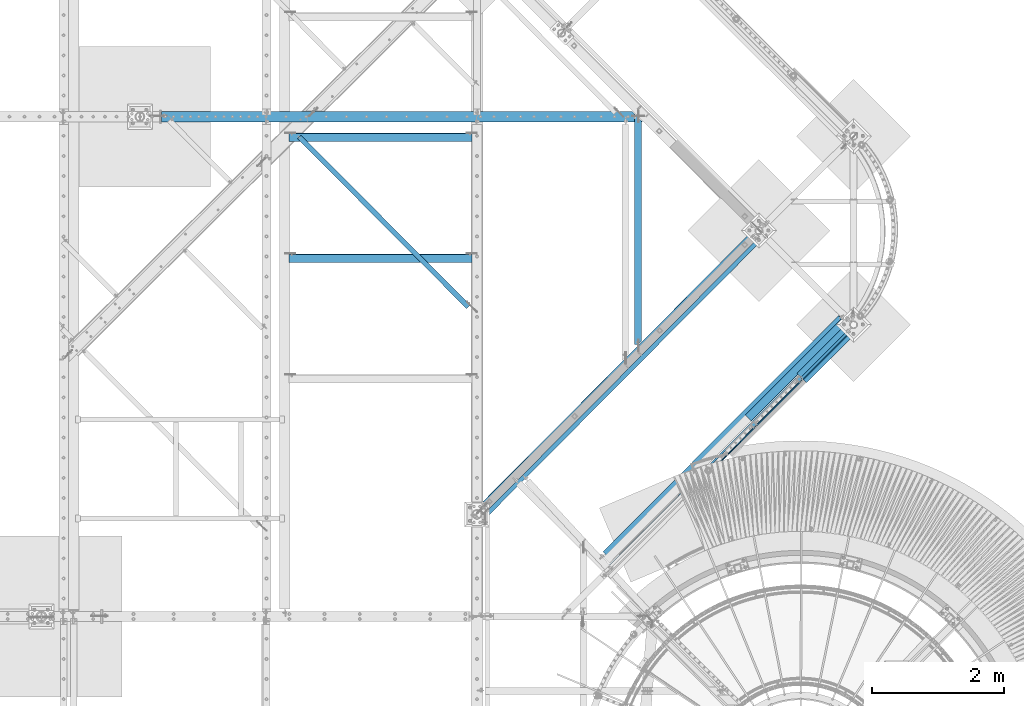
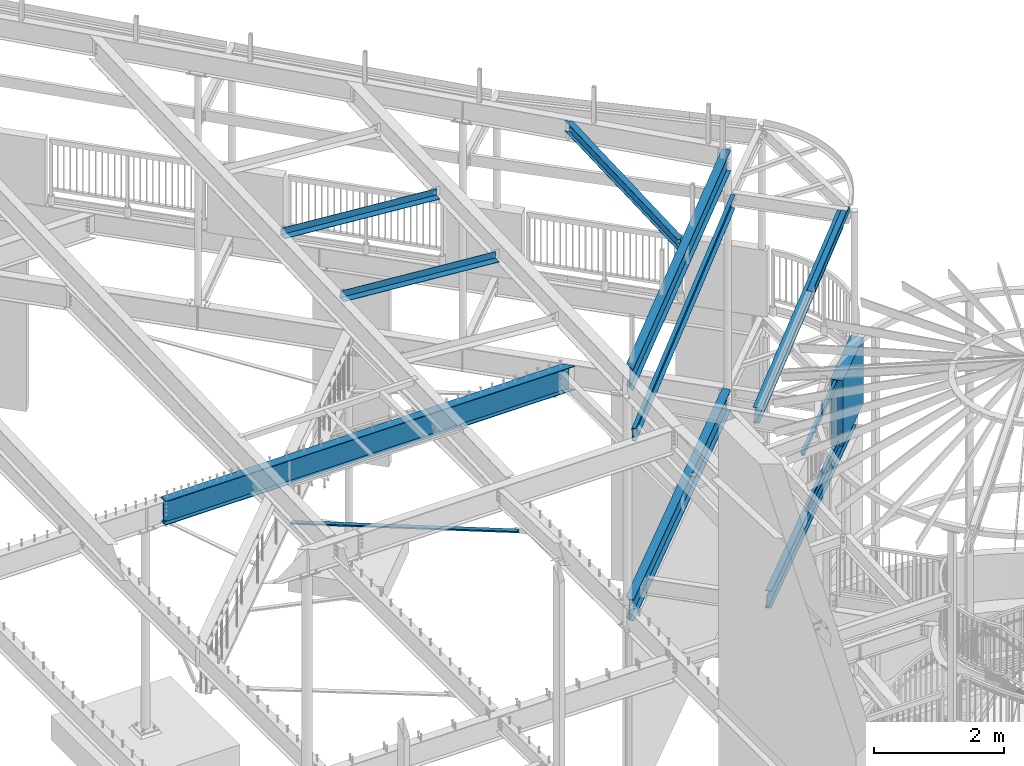
# One storey, part 369 of 975: 14 beams.
"""IFC2X3 building model written with IfcOpenShell, lengths in millimetres."""

from ifc_helpers import new_model, si_unit, frame, origin_with_axes, place, context, subcontext, project, spatial, faceted_brep, material, type_object, element, save


model = new_model("IFC2X3")

# Units and contexts
model_context = context("Model", 3, precision=1e-05, world=origin_with_axes())
body_context = subcontext(model_context, "Body", "Model", "MODEL_VIEW")
ifc_project = project(units=[si_unit("LENGTHUNIT", "METRE", prefix="MILLI"), si_unit("AREAUNIT", "SQUARE_METRE"), si_unit("VOLUMEUNIT", "CUBIC_METRE"), si_unit("MASSUNIT", "GRAM", prefix="KILO"), si_unit("TIMEUNIT", "SECOND"), si_unit("PLANEANGLEUNIT", "RADIAN"), si_unit("SOLIDANGLEUNIT", "STERADIAN"), si_unit("THERMODYNAMICTEMPERATUREUNIT", "DEGREE_CELSIUS"), si_unit("LUMINOUSINTENSITYUNIT", "LUMEN")], contexts=[model_context])

# Site, building, storey
site_placement = place(None, origin_with_axes())
site = spatial("IfcSite", under=ifc_project, at=site_placement, CompositionType="ELEMENT")
building_placement = place(site_placement, origin_with_axes())
building = spatial("IfcBuilding", under=site, at=building_placement, Name="Undefined", CompositionType="ELEMENT")
storey_placement = place(building_placement, origin_with_axes())
storey = spatial("IfcBuildingStorey", under=building, at=storey_placement, Name="Undefined", CompositionType="ELEMENT", Elevation=0.0)

# Beams
ifc_material_1 = material(Name="STEEL/A36")
beam_type_1 = type_object("IfcBeamType", Name="L3X3X3/16", PredefinedType="NOTDEFINED")
beam_1_placement = place(storey_placement, frame((27168.4576341106, 13059.2154433271, 2870.2), z_axis=(-0.709199630836852, -0.705007718837796, 0.0), x_axis=(0.0, 0.0, 1.0)))
element("IfcBeam", 1, at=beam_1_placement, inside=storey, type_object=beam_type_1, material=ifc_material_1, Name="ANGLE", ObjectType="L3X3X3/16", context=body_context, shape_type="Brep", body=[
    faceted_brep([(25.4000008288263, 33.3375000029282, 38.0998593531185), (25.4000000579194, 38.1000000029326, 38.0998593531222), (25.4000000057686, 38.1000000029999, -38.1001406479627), (25.4000007766758, 33.337499976793, -38.0997502874998), (25.400000779935, 33.3375000029864, -33.3376406479038), (87.9265310704686, 33.3375000605593, -33.3379868761476), (87.9265310672095, 33.3374998672407, -38.1002658450525), (17.1664076945221, 23.5263180373422, -38.1000950560956), (17.1664578788032, 23.5263251884717, -33.3375950563059), (25.7799495100917, -38.5952650544987, -33.338294942936), (25.7107114156174, -38.0999999970863, -33.337642368464), (25.7106039629884, -38.0999999970791, -38.1001423679409), (25.7799104735986, -38.5951737114028, -38.1007949418963), (519.883321706701, -3602.16366419144, -38.1731929346388), (519.883347554101, -3602.16366041227, -33.4106929337468), (101.257834322486, -28.1298494790972, -38.1012128859002), (92.0741449431193, 38.1000000106342, -38.1005098427995), (92.0758641851835, 38.1000000105723, 38.099490148772), (101.258458906369, -28.1313109686234, 38.0987870974495), (595.361659118978, -3591.69827952844, 38.0263891356226), (595.361245560576, -3591.69833999513, -38.173610878639), (96.5410886658128, -28.7853937331438, 38.098813218945), (590.64428887811, -3592.35236229071, 38.0264152571253), (590.643901167109, -3592.35241897823, -33.4110847562479), (87.928142873925, 33.3375000100896, 38.0995131159507), (96.5405031184227, -28.7840235867134, -33.3386867654408)], [[[0, 1, 2, 3, 4]], [[5, 6, 7, 8]], [[4, 3, 6, 5]], [[9, 10, 11, 12, 13, 14]], [[15, 16, 17, 18, 19, 20]], [[18, 21, 22, 19]], [[23, 14, 13, 20, 19, 22]], [[21, 24, 5, 25, 23, 22]], [[10, 9, 14, 23, 25, 5, 8]], [[11, 10, 8, 7]], [[2, 16, 15, 20, 13, 12, 11, 7, 6, 3]], [[17, 16, 2, 1]], [[24, 21, 18, 17, 1, 0]], [[5, 24, 0, 4]]]),
])
beam_type_2 = type_object("IfcBeamType", Name="C10X15.3", PredefinedType="NOTDEFINED")
beam_2_placement = place(storey_placement, frame((29910.7374267626, 7300.12961301869, 7137.61804652991), z_axis=(-0.0412871090037879, -0.0415479340038119, 0.998283098028873), x_axis=(0.703666593898344, 0.708111903897702, 0.058573510991538)))
element("IfcBeam", 2, at=beam_2_placement, inside=storey, type_object=beam_type_2, material=ifc_material_1, Name="BEAM", ObjectType="C10X15.3", context=body_context, shape_type="Brep", body=[
    faceted_brep([(-1.70985003933311e-10, 33.3375000000001, -126.999999999975), (1.78260961547494e-10, 33.3375000000001, 126.999999999975), (6001.03386350567, 33.3375000025826, 127.000000000959), (5986.13060427879, 33.337500002357, -126.999999999053), (1.78260961547494e-10, -33.3375000000001, 126.999999999975), (6001.03386353988, -33.3374999974276, 127.000000000962), (1.70985003933311e-10, -33.3375000000001, 121.441527499974), (6000.70772434078, -33.3374999974294, 121.441527500961), (1.52795109897852e-10, 26.9875000000002, 111.391382499978), (6000.11803960036, 26.9875000025695, 111.391382500958), (-1.4915713109076e-10, 26.9875000000002, -111.391382499976), (5987.04642819061, 26.9875000023676, -111.391382499053), (-1.63709046319127e-10, -33.3375000000001, -121.44152749997), (5986.45674351211, -33.3374999976459, -121.441527499051), (-1.70985003933311e-10, -33.3375000000001, -126.999999999975), (5986.130604313, -33.3374999976513, -126.99999999905)], [[[0, 1, 2, 3]], [[1, 4, 5, 2]], [[4, 6, 7, 5]], [[6, 8, 9, 7]], [[8, 10, 11, 9]], [[10, 12, 13, 11]], [[12, 14, 15, 13]], [[14, 0, 3, 15]], [[5, 7, 9, 11, 13, 15, 3, 2]], [[14, 12, 10, 8, 6, 4, 1, 0]]]),
])
ifc_material_2 = material()
beam_type_3 = type_object("IfcBeamType", Name="HSS2X4X.188_TUBES", PredefinedType="NOTDEFINED")
beam_3_placement = place(storey_placement, frame((33335.0272322989, 8032.31295386229, 5130.8), z_axis=(0.0, 0.0, 1.0), x_axis=(0.706220613094393, 0.70799184009463, 0.0)))
element("IfcBeam", 3, at=beam_3_placement, inside=storey, type_object=beam_type_3, material=ifc_material_2, Name="GUARDRAIL", ObjectType="HSS2X4X.188_TUBES", context=body_context, shape_type="Brep", body=[
    faceted_brep([(23.0189099507188, 20.6374999999716, -46.0375000000004), (23.0189099506351, -20.6374999999425, -46.0375000000004), (1932.78143844252, -20.6374999989494, -46.0375000000004), (1932.78143844261, 20.6375000009684, -46.0375000000004), (-23.0189087615618, -20.6374999999716, 46.0375000000004), (1978.81925715473, -20.6374999989275, 46.0375000000004), (-23.0189087614854, 20.6374999999534, 46.0375000000004), (1978.8192571548, 20.6375000009975, 46.0375000000004), (25.40017643584, 25.3999999999687, -50.8000000000002), (-25.4001752465883, 25.3999999999396, 50.8000000000002), (1981.20052363992, 25.4000000009873, 50.8000000000002), (1930.4001719575, 25.4000000009619, -50.8000000000002), (-25.4001752466866, -25.3999999999651, 50.8000000000002), (1981.20052363983, -25.3999999989137, 50.8000000000002), (25.4001764357381, -25.399999999936, -50.8000000000002), (1930.4001719574, -25.3999999989428, -50.8000000000002)], [[[0, 1, 2, 3]], [[1, 4, 5, 2]], [[4, 6, 7, 5]], [[6, 0, 3, 7]], [[8, 9, 10, 11]], [[9, 12, 13, 10]], [[12, 14, 15, 13]], [[14, 8, 11, 15]], [[13, 15, 11, 10], [5, 7, 3, 2]], [[14, 12, 9, 8], [6, 4, 1, 0]]]),
])
beam_type_4 = type_object("IfcBeamType", Name="L5X5X5/16", PredefinedType="NOTDEFINED")
for number, where, z_axis, x_axis in (
    (4, (26920.8249998945, 11250.4718563048, 8374.05719665839), (0.0796654699609281, 0.0, 0.996821655511107), (0.996821655511107, 0.0, -0.0796654699609281)),
    (5, (26920.8249998945, 13079.2718563048, 8450.05353907804), (0.0796654699609281, 0.0, 0.996821655511107), (0.996821655511107, 0.0, -0.0796654699609281)),
):
    element("IfcBeam", number, at=place(storey_placement, frame(where, z_axis=z_axis, x_axis=x_axis)), inside=storey, type_object=beam_type_4, material=ifc_material_1, ObjectType="L5X5X5/16", context=body_context, shape_type="Brep", body=[
        faceted_brep([(67.8053474811386, 63.5, -63.5000000000291), (67.805347481346, 63.5, 63.5000000000564), (2852.95282830662, 63.5, 63.5000000004839), (2852.9528283064, 63.5, -63.4999999996035), (67.805347481346, 55.5625, 63.5000000000564), (2852.95282830662, 55.5625, 63.5000000004839), (67.8053474811495, 55.5625, -55.5625000000236), (2852.95282830642, 55.5625, -55.562499999598), (67.8053474811495, -63.5, -55.5625000000236), (2852.95282830642, -63.5, -55.562499999598), (67.8053474811386, -63.5, -63.5000000000291), (2852.9528283064, -63.5, -63.4999999996035)], [[[0, 1, 2, 3]], [[1, 4, 5, 2]], [[4, 6, 7, 5]], [[6, 8, 9, 7]], [[8, 10, 11, 9]], [[10, 0, 3, 11]], [[5, 7, 9, 11, 3, 2]], [[10, 8, 6, 4, 1, 0]]]),
    ])
beam_type_5 = type_object("IfcBeamType", PredefinedType="NOTDEFINED")
beam_4_placement = place(storey_placement, frame((34527.3123904943, 9227.9224403848, 3938.58749694824), z_axis=(-0.706192932930278, -0.708019449930108, 0.0), x_axis=(0.708019449930107, -0.706192932930278, 0.0)))
element("IfcBeam", 6, at=beam_4_placement, inside=storey, type_object=beam_type_5, material=ifc_material_1, Name="DECK_EDGE", context=body_context, shape_type="Brep", body=[
    faceted_brep([(1.03318598121405e-09, -1.58750000000009, -1524.00000000109), (-1.04046193882823e-09, -1.58750000000009, 1524.0000000011), (-1.04046193882823e-09, 1.58750000000009, 1524.0000000011), (1.03318598121405e-09, 1.58750000000009, -1524.00000000109), (47.6250001214066, 1.58750000000009, 1524.00000000113), (47.6250001235167, 1.58750000000009, -1524.00000000107), (50.8000001235196, -1.58750000000009, -1524.00000000106), (50.8000001214168, -1.58750000000009, 1524.00000000113), (47.6250001214503, 96.837499999901, 1524.00000000113), (47.625000123473, 96.8374999999951, -1524.00000000106), (50.8000001234759, 104.502628762961, -1524.00000000106), (50.8000001214605, 104.502628762867, 1524.00000000113), (38.6447461584321, 87.8572448731024, 1524.00000000113), (38.6447461604548, 87.8572448731024, -1524.00000000107), (36.3996819826862, 90.102308757891, 1524.00000000112), (36.3996819847016, 90.102308757891, -1524.00000000107)], [[[0, 1, 2, 3]], [[3, 2, 4, 5]], [[1, 0, 6, 7]], [[5, 4, 8, 9]], [[7, 6, 10, 11]], [[9, 8, 12, 13]], [[8, 4, 2, 1, 7, 11, 14, 12]], [[11, 10, 15, 14]], [[10, 6, 0, 3, 5, 9, 13, 15]], [[14, 15, 13, 12]]]),
])
beam_type_6 = type_object("IfcBeamType", PredefinedType="NOTDEFINED")
beam_5_placement = place(storey_placement, frame((34625.9997480697, 9604.01899476604, 7559.40335706271), z_axis=(-0.704820138136317, -0.706998290775193, -0.0581548769963319), x_axis=(0.708196855160895, -0.706015024160385, 1.72999999439031e-07)))
element("IfcBeam", 7, at=beam_5_placement, inside=storey, type_object=beam_type_6, material=ifc_material_1, Name="DECK_EDGE", context=body_context, shape_type="Brep", body=[
    faceted_brep([(-8.80390871316195e-09, -3.17500000022574, -1035.04999999823), (2.11002770811319e-09, -3.17499999977372, 1035.04999999821), (8.80027073435485e-09, 3.17500000022756, 1035.04999999823), (-2.11730366572738e-09, 3.17499999977372, -1035.04999999822), (127.239425700831, 3.17499986607436, 1035.04999999815), (127.239425684118, 3.17499986562143, -1035.04999999829), (133.589575920003, -3.17500014107372, -1035.04999999831), (133.589575936709, -3.1750001406208, 1035.04999999815), (127.236871721263, 111.12485451768, 1035.049999998), (127.236871710345, 111.12485451143, -1035.04999999845), (133.586871719464, 111.125004751796, 1035.049999998), (133.58687170855, 111.125004745548, -1035.04999999845)], [[[0, 1, 2, 3]], [[3, 2, 4, 5]], [[1, 0, 6, 7]], [[5, 4, 8, 9]], [[4, 2, 1, 7, 10, 8]], [[7, 6, 11, 10]], [[6, 0, 3, 5, 9, 11]], [[10, 11, 9, 8]]]),
])
ifc_material_3 = material(Name="CONCRETE/5000")
beam_type_7 = type_object("IfcBeamType", PredefinedType="NOTDEFINED")
beam_6_placement = place(storey_placement, frame((34754.1236185556, 9432.06344327084, 4559.3), z_axis=(0.0, 0.0, 1.0), x_axis=(0.706311124041062, 0.707901544041155, 0.0)))
element("IfcBeam", 8, at=beam_6_placement, inside=storey, type_object=beam_type_7, material=ifc_material_3, Name="LOW WALL", context=body_context, shape_type="Brep", body=[
    faceted_brep([(8.00355337560177e-11, 101.599999999831, -622.3), (8.00355337560177e-11, 101.599999999831, 622.3), (1219.20000000123, 101.599999998936, 622.3), (1219.20000000123, 101.599999998936, -622.3), (-7.27595761418343e-11, -101.599999999831, 622.3), (1219.20000000109, -101.600000000741, 622.3), (-7.27595761418343e-11, -101.599999999831, -622.3), (1219.20000000109, -101.600000000741, -622.3)], [[[0, 1, 2, 3]], [[1, 4, 5, 2]], [[4, 6, 7, 5]], [[6, 0, 3, 7]], [[5, 7, 3, 2]], [[6, 4, 1, 0]]]),
])
ifc_material_4 = material(Name="STEEL/A992")
beam_type_8 = type_object("IfcBeamType", Name="W8X10", PredefinedType="NOTDEFINED")
beam_7_placement = place(storey_placement, frame((32270.7000000007, 9825.29369643643, 8292.85227477858), z_axis=(0.0, 0.0390147299837681, -0.99923863558426), x_axis=(0.0, 0.99923863558426, 0.0390147299837675)))
element("IfcBeam", 9, at=beam_7_placement, inside=storey, type_object=beam_type_8, material=ifc_material_4, Name="BEAM", ObjectType="W8X10", context=body_context, shape_type="Brep", body=[
    faceted_brep([(160.737852590288, 50.7999999999993, 95.2499999999636), (160.551903363616, 50.7999999999993, 100.012499999964), (3506.64939208805, 50.7999999999993, 100.012499999042), (3506.83534131949, 50.7999999999993, 95.2499999990414), (3616.17310180885, -50.7999999999993, -100.012500001006), (3615.98715257741, -50.7999999999993, -95.250000001005), (119.414067826492, -50.7999999999993, -95.2500000000418), (119.600017053164, -50.7999999999993, -100.012500000041), (168.361770883843, 50.7999999999993, -100.012500000055), (3514.45925980861, 50.7999999999993, -100.012500000978), (119.600017053164, 2.38124999972206, -100.012500000041), (168.175821657171, 50.7999999999993, -95.2500000000546), (119.414067826774, 2.38124999999854, -95.2500000000418), (3555.30834414774, 2.38124999999854, 95.2499999990278), (3562.74631340541, 2.38124999999854, -95.2500000009904), (111.976098759891, 2.38124999999854, 95.2499999999782), (3514.27331057716, 50.7999999999993, -95.2500000009786), (3608.3632340883, -50.7999999999993, 100.012499999014), (3608.54918331974, -50.7999999999993, 95.2499999990114), (3560.0761804915, -2.38124999999854, 95.249999999025), (3567.51414974917, -2.38124999999854, -95.2500000009923), (111.790149532939, 2.38124999972206, 100.012499999977), (111.790149532939, -50.7999999999993, 100.012499999977), (111.976098759611, -50.7999999999993, 95.2499999999782), (111.976098759611, -2.38124999999854, 95.2499999999782), (119.414067826492, -2.38124999999854, -95.2500000000418)], [[[0, 1, 2, 3]], [[4, 5, 6, 7]], [[8, 9, 4, 7, 10]], [[11, 8, 10, 12]], [[13, 14, 12, 15]], [[11, 12, 14, 16]], [[8, 11, 16, 9]], [[14, 13, 3, 2, 17, 18, 19, 20, 5, 4, 9, 16]], [[15, 0, 3, 13]], [[1, 0, 15, 21]], [[17, 2, 1, 21, 22]], [[18, 17, 22, 23]], [[19, 18, 23, 24]], [[20, 19, 24, 25]], [[5, 20, 25, 6]], [[24, 23, 22, 21, 15, 12, 10, 7, 6, 25]]]),
])
beam_type_9 = type_object("IfcBeamType", Name="W12X14", PredefinedType="NOTDEFINED")
beam_8_placement = place(storey_placement, frame((31701.1565014444, 6689.96021302115, 7164.64273981511), z_axis=(0.0410754901247674, 0.0411679811250478, -0.998307568558457), x_axis=(0.70511574104899, 0.7067034690491, 0.0581549530040405)))
element("IfcBeam", 10, at=beam_8_placement, inside=storey, type_object=beam_type_9, material=ifc_material_4, Name="BEAM", ObjectType="W12X14", context=body_context, shape_type="Brep", body=[
    faceted_brep([(25.2283139935607, -2.38124999992942, -119.062499999896), (25.0388399786862, 2.3812500000713, -119.062499999894), (102.641346061158, 2.38125000011496, -119.062500000057), (102.641346061147, -2.38124999988577, -119.062500000056), (107.501425579212, 2.38125000012224, -120.02922992265), (107.501425579201, -2.38124999988213, -120.02922992265), (111.621602047373, 2.38125000012224, -122.782243823133), (111.621602047366, -2.38124999988213, -122.782243823132), (114.374615947854, 2.38125000012951, -126.902420291292), (114.374615947851, -2.38124999987485, -126.902420291291), (115.341345870445, -2.38124999987485, -131.762499809341), (115.341345870453, 2.38125000012587, -131.762499809339), (115.341345870569, 2.38125000013315, -144.462500000049), (115.341345870547, 50.8000000001666, -144.462500000039), (115.341345870544, 50.8000000001703, -150.812500000039), (115.341345870602, -50.799999999901, -150.812499796145), (115.341345870602, -50.7999999999047, -144.462500000061), (115.341345870573, -2.38124999987122, -144.46250000005), (5162.38062903908, 50.8000000028551, 144.462499998789), (5162.38062903895, 2.38125000281434, 144.462499998778), (108.991345869556, 2.38124999999854, 144.462499999994), (108.991345869523, 50.800000000032, 144.462500000005), (96.2913460602103, -2.38124999999854, 119.062500000006), (96.291346060214, 2.38125000000218, 119.062500000006), (11.1672150216582, 2.38124999995489, 119.062499999933), (11.3566890365291, -2.38125000005311, 119.06249999993), (101.151425578257, -2.38124999999854, 120.02922992259), (101.151425578264, 2.38125000000218, 120.029229922589), (105.271602046414, -2.38124999999854, 122.782243823064), (105.271602046421, 2.38125000000582, 122.782243823064), (108.024615946892, -2.38124999999854, 126.902420291218), (108.024615946895, 2.38125000000582, 126.902420291217), (108.991345869472, -2.38125000000218, 131.762499809265), (108.991345869475, 2.38124999999854, 131.762499809264), (5162.38062903881, -50.7999999972235, 150.812499998767), (5162.38062903909, 50.8000000028442, 150.812499998789), (108.991345869523, 50.8000000000284, 150.812500000005), (108.991345869577, -50.8000000000429, 150.812499999982), (5162.38062903881, -50.7999999972199, 144.462499998765), (108.991345869581, -50.8000000000393, 144.462499999981), (5162.38062903893, -2.38124999718639, 144.462499998776), (108.991345869559, -2.38125000000582, 144.462499999993), (5162.38062903889, -2.38124999716092, 93.6624998101788), (5162.38062903889, 2.38125000283981, 93.6624998101788), (5163.34735896147, -2.38124999716456, 88.8024202921251), (5163.34735896148, 2.38125000283981, 88.802420292126), (5166.10037286195, -2.38124999715728, 84.6822438239642), (5166.10037286195, 2.38125000284344, 84.6822438239642), (5170.2205493301, -2.38124999715001, 81.9292299234785), (5170.22054933012, 2.38125000285072, 81.9292299234785), (5175.08062884814, -2.38124999715365, 80.9625000008828), (5175.08062884815, 2.38125000285072, 80.9625000008828), (5212.29092933559, -2.38124999712818, 80.9625000009428), (5212.29880857402, 2.38125000287619, 80.9625000009482), (5224.31300429969, -2.38124999702632, -125.412499999199), (5224.32088353811, 2.38125000297441, -125.412499999194), (5187.78062884838, -2.38124999704814, -125.412499999195), (5187.78062884838, 2.38125000295622, -125.412499999195), (5182.92054933034, -2.38124999704814, -126.379229921779), (5182.92054933034, 2.38125000295258, -126.379229921779), (5178.8003728622, -2.38124999705178, -129.132243822253), (5178.80037286221, 2.38125000295258, -129.132243822253), (5176.04735896172, -2.38124999705178, -133.252420290401), (5176.04735896173, 2.38125000295258, -133.252420290401), (5175.08062903914, -2.38124999704814, -138.112499808442), (5175.08062903915, 2.38125000295258, -138.112499808442), (5175.08062903919, -2.38124999704451, -144.462500001267), (5175.08062903907, -50.799999997078, -144.462500001278), (5175.08062903906, -50.7999999970743, -150.81250000128), (5175.08062903933, 50.800000002997, -150.812500001256), (5175.08062903933, 50.8000000029933, -144.462500001256), (5175.0806290392, 2.38125000295986, -144.462500001267)], [[[0, 1, 2, 3]], [[3, 2, 4, 5]], [[5, 4, 6, 7]], [[7, 6, 8, 9]], [[10, 11, 12, 13, 14, 15, 16, 17]], [[9, 8, 11, 10]], [[18, 19, 20, 21]], [[22, 23, 24, 25]], [[26, 27, 23, 22]], [[28, 29, 27, 26]], [[30, 31, 29, 28]], [[32, 33, 31, 30]], [[34, 35, 36, 37]], [[38, 34, 37, 39]], [[40, 38, 39, 41]], [[37, 36, 21, 20, 33, 32, 41, 39]], [[35, 18, 21, 36]], [[34, 38, 40, 42, 43, 19, 18, 35]], [[44, 45, 43, 42]], [[46, 47, 45, 44]], [[48, 49, 47, 46]], [[50, 51, 49, 48]], [[52, 53, 51, 50]], [[53, 52, 54, 55]], [[54, 56, 57, 55]], [[58, 59, 57, 56]], [[60, 61, 59, 58]], [[62, 63, 61, 60]], [[64, 65, 63, 62]], [[66, 67, 68, 69, 70, 71, 65, 64]], [[67, 66, 17, 16]], [[68, 67, 16, 15]], [[69, 68, 15, 14]], [[70, 69, 14, 13]], [[71, 70, 13, 12]], [[6, 4, 2, 1, 24, 23, 27, 29, 31, 33, 20, 19, 43, 45, 47, 49, 51, 53, 55, 57, 59, 61, 63, 65, 71, 12, 11, 8]], [[25, 24, 1, 0]], [[66, 64, 62, 60, 58, 56, 54, 52, 50, 48, 46, 44, 42, 40, 41, 32, 30, 28, 26, 22, 25, 0, 3, 5, 7, 9, 10, 17]]]),
])
beam_type_10 = type_object("IfcBeamType", Name="W16X26", PredefinedType="NOTDEFINED")
beam_9_placement = place(storey_placement, frame((29835.8443041473, 7371.1541947718, 8105.83821059633), z_axis=(0.0177193059303681, 0.0178312450520461, -0.999683986516359), x_axis=(0.704654047239519, 0.709105596241033, 0.0251381600085448)))
element("IfcBeam", 11, at=beam_9_placement, inside=storey, type_object=beam_type_10, material=ifc_material_4, Name="BEAM", ObjectType="W16X26", context=body_context, shape_type="Brep", body=[
    faceted_brep([(214.497715443573, -69.8499999999931, -200.024999999975), (73.8707410833849, 69.8499999999713, -200.024999999954), (5979.94834157897, 69.8500000029326, -200.024999998341), (5979.94834159622, -57.1922631835241, -200.024999998393), (5979.94834159794, -69.8499999970973, -200.0249999984), (214.258198778149, -69.8499999999876, -190.499999999975), (147.140779197147, -3.17500000000655, -190.499999999965), (137.560112580046, -3.1749999998483, 190.500000000039), (204.677532161048, -69.8499999998294, 190.50000000003), (204.43801549562, -69.8499999998276, 200.02500000003), (63.8110411354282, 69.8500000001332, 200.025000000049), (64.0505578008524, 69.8500000001313, 190.500000000048), (131.167977381854, 3.17500000015207, 190.50000000004), (140.748643998959, 3.17499999999382, -190.499999999965), (73.6312244179535, 69.8499999999767, -190.499999999956), (5979.70882493337, -69.8499999970954, -190.499999998397), (5979.70882493165, -57.1922631843718, -190.499999998392), (5979.70882492431, -3.17499999708161, -190.499999998371), (5970.1281583414, -3.17499999692336, 190.500000001633), (5970.12815834874, -57.1922632181795, 190.500000001612), (5970.12815835046, -69.8499999969335, 190.500000001605), (5969.88864168589, -69.8499999969354, 200.025000001606), (5969.88864168417, -57.1922632190272, 200.02500000161), (5969.88864166691, 69.8500000030981, 200.025000001663), (5970.12815833149, 69.8500000030963, 190.500000001663), (5970.12815834054, 3.17500000307882, 190.500000001635), (5979.70882492345, 3.17500000292421, -190.499999998368), (5979.70882491439, 69.850000002938, -190.499999998341)], [[[0, 1, 2, 3, 4]], [[0, 5, 6, 7, 8, 9, 10, 11, 12, 13, 14, 1]], [[6, 5, 15, 16, 17]], [[7, 6, 17, 18]], [[8, 7, 18, 19, 20]], [[9, 8, 20, 21]], [[10, 9, 21, 22, 23]], [[11, 10, 23, 24]], [[12, 11, 24, 25]], [[13, 12, 25, 26]], [[14, 13, 26, 27]], [[1, 14, 27, 2]], [[26, 25, 24, 23, 22, 21, 20, 19, 18, 17, 16, 15, 4, 3, 2, 27]], [[5, 0, 4, 15]]]),
])
beam_10_placement = place(storey_placement, frame((29832.3, 7371.64209438365, 3736.975), z_axis=(0.0, 0.0, 1.0), x_axis=(0.705211376647206, 0.708997118645311, 0.0)))
element("IfcBeam", 12, at=beam_10_placement, inside=storey, type_object=beam_type_10, material=ifc_material_4, Name="BEAM", ObjectType="W16X26", context=body_context, shape_type="Brep", body=[
    faceted_brep([(196.286465762245, 69.8500000000186, -190.5), (196.286465762245, 69.8500000000186, -200.025), (129.253538539953, 3.17499999780557, -200.025), (129.253538542107, 3.17499999994834, -190.5), (5987.87903855044, 3.17499999739812, 190.5), (5987.87903855044, 3.17499999739812, -190.5), (129.253538542107, 3.17499999994834, 190.5), (5968.82934258171, 69.8499999975029, -190.5), (5987.87903855032, 57.1500001832374, -190.5), (5968.82934258171, 57.2574602052428, -190.5), (5968.82934258171, 69.8499999975029, -200.025), (5968.82934258171, 57.2574602052428, -200.025), (5987.87903855037, 57.1500001832337, -200.025), (5968.8293425819, -69.8500000027052, -190.5), (5968.8293425819, -69.8500000027052, -200.025), (5968.8293425819, -57.0425401765897, -200.025), (5968.8293425819, -57.0425401765897, -190.5), (129.253538539953, -69.8500000001586, -190.5), (129.253538539953, -69.8500000001586, -200.025), (5987.87903855052, -57.1500001985987, -200.025), (5987.87903855055, -57.1500001985951, -190.5), (5987.87903855045, -3.17500000261134, -190.5), (129.253538539953, -3.17500000006112, -190.5), (5987.87903855045, -3.17500000261134, 190.5), (129.253538539953, -3.17500000006112, 190.5), (5968.8293425819, -69.8500000027052, 200.025), (5968.8293425819, -69.8500000027052, 190.5), (5968.8293425819, -57.0425401765897, 190.5), (5968.8293425819, -57.0425401765897, 200.025), (129.253538539953, -69.8500000001586, 200.025), (129.253538539953, -69.8500000001586, 190.5), (5987.87903855052, -57.1500001985987, 190.5), (5987.87903855055, -57.1500001985951, 200.025), (5987.87903855037, 57.1500001832337, 190.5), (5987.87903855032, 57.1500001832374, 200.025), (196.286465762245, 69.8500000000186, 190.5), (196.286465762245, 69.8500000000186, 200.025), (5968.82934258171, 69.8499999975029, 200.025), (5968.82934258171, 69.8499999975029, 190.5), (5968.82934258171, 57.2574602052428, 200.025), (5968.82934258171, 57.2574602052428, 190.5), (129.253538539953, 3.17499999780557, 200.025)], [[[0, 1, 2, 3]], [[4, 5, 3, 6]], [[7, 0, 3, 5, 8, 9]], [[1, 0, 7, 10]], [[9, 11, 10, 7]], [[8, 12, 11, 9]], [[13, 14, 15, 16]], [[14, 13, 17, 18]], [[1, 10, 11, 12, 19, 15, 14, 18, 2]], [[20, 16, 15, 19]], [[13, 16, 20, 21, 22, 17]], [[21, 23, 24, 22]], [[25, 26, 27, 28]], [[26, 25, 29, 30]], [[23, 31, 27, 26, 30, 24]], [[32, 28, 27, 31]], [[23, 21, 20, 19, 12, 8, 5, 4, 33, 34, 32, 31]], [[35, 36, 37, 38]], [[39, 40, 38, 37]], [[34, 33, 40, 39]], [[4, 6, 35, 38, 40, 33]], [[36, 35, 6, 41]], [[25, 28, 32, 34, 39, 37, 36, 41, 29]], [[6, 3, 2, 18, 17, 22, 24, 30, 29, 41]]]),
])
beam_type_11 = type_object("IfcBeamType", Name="W18X35", PredefinedType="NOTDEFINED")
beam_11_placement = place(storey_placement, frame((25036.4625, 13392.15, 3711.575), z_axis=(0.0, 0.0, 1.0), x_axis=(1.0, 0.0, 0.0)))
element("IfcBeam", 13, at=beam_11_placement, inside=storey, type_object=beam_type_11, material=ifc_material_4, Name="BEAM", ObjectType="W18X35", context=body_context, shape_type="Brep", body=[
    faceted_brep([(14.287031462678, -76.1999999999998, 225.425), (14.287031462678, 76.1999999999998, 225.425), (3.17496870515606, 76.1999999999998, 214.312499999999), (3.17496870515606, 3.96875, 214.312499999999), (2.77798382235414, 3.96875, 213.915499496458), (2.77798382235414, -3.96875, 213.915499496458), (3.17496870515606, -3.96875, 214.312499999999), (3.17496870515606, -76.1999999999998, 214.312499999999), (22.2250007629409, -3.96875, 213.915499496458), (22.2250007629409, 3.96875, 213.915499496458), (40.7122683048001, 3.96875, 203.575605287907), (40.7122683048001, -3.96875, 203.575605287907), (44.8249534620081, 3.96875, 198.997422721183), (44.8249534620081, -3.96875, 198.997422721183), (45.2798117862694, 3.96875, 192.860074863892), (45.2798117862694, -3.96875, 192.860074863892), (41.8869600345242, 3.96875, 187.725633140859), (41.8869600345242, -3.96875, 187.725633140859), (36.0627638298283, 3.96875, 185.737499999999), (36.0627638298283, -3.96875, 185.737499999999), (6.34999999999854, 3.96875, 185.737499999999), (6.34999999999854, -3.96875, 185.737499999999), (6.34999999999854, 3.96875, -185.7375), (6.34999999999854, -3.96875, -185.7375), (47.9687625480874, 3.96875, -185.7375), (47.9687625480874, -3.96875, -185.7375), (53.7929587527833, 3.96875, -187.72563314086), (53.7929587527833, -3.96875, -187.72563314086), (57.1858105045285, 3.96875, -192.860074863893), (57.1858105045285, -3.96875, -192.860074863893), (56.7309521802672, 3.96875, -198.997422721185), (56.7309521802672, -3.96875, -198.997422721185), (52.6182670230592, 3.96875, -203.575605287907), (52.6182670230592, -3.96875, -203.575605287907), (34.1309994812, 3.96875, -213.91549949646), (34.1309994812, -3.96875, -213.91549949646), (14.6840158801024, 3.96875, -213.91549949646), (14.6840158801024, -3.96875, -213.91549949646), (7223.08903002124, 3.96875, -214.3125), (7151.28471014972, 76.2000000000007, -214.3125), (14.2870309973041, 76.1999999999998, -214.3125), (14.2870309973041, 3.96875, -214.3125), (7151.28471014972, 76.2000000000007, -225.425), (7302.78393449401, -76.2000000000007, -225.425), (3.17496823977854, -76.1999999999998, -225.425), (3.17496823977854, 76.1999999999998, -225.425), (7302.78393449401, -76.2000000000007, -214.3125), (14.2870309973041, -76.1999999999998, -214.3125), (7230.9796146225, -3.96875, -214.3125), (14.2870309973041, -3.96875, -214.3125), (7223.08903002124, 3.96875, 214.3125), (7151.28471014972, 76.2000000000007, 214.3125), (7151.28471014972, 76.2000000000007, 225.425), (7302.78393449401, -76.2000000000007, 225.425), (7302.78393449401, -76.2000000000007, 214.3125), (7230.9796146225, -3.96875, 214.3125)], [[[0, 1, 2, 3, 4, 5, 6, 7]], [[8, 9, 10, 11]], [[11, 10, 12, 13]], [[13, 12, 14, 15]], [[15, 14, 16, 17]], [[17, 16, 18, 19]], [[19, 18, 20, 21]], [[21, 20, 22, 23]], [[24, 25, 23, 22]], [[25, 24, 26, 27]], [[27, 26, 28, 29]], [[29, 28, 30, 31]], [[31, 30, 32, 33]], [[33, 32, 34, 35]], [[35, 34, 36, 37]], [[38, 39, 40, 41]], [[42, 43, 44, 45]], [[43, 46, 47, 44]], [[46, 48, 49, 47]], [[37, 36, 41, 40, 45, 44, 47, 49]], [[39, 42, 45, 40]], [[38, 50, 51, 52, 53, 54, 55, 48, 46, 43, 42, 39]], [[54, 53, 0, 7]], [[55, 54, 7, 6]], [[8, 11, 13, 15, 17, 19, 21, 23, 25, 27, 29, 31, 33, 35, 37, 49, 48, 55, 6, 5]], [[9, 8, 5, 4]], [[50, 38, 41, 36, 34, 32, 30, 28, 26, 24, 22, 20, 18, 16, 14, 12, 10, 9, 4, 3]], [[51, 50, 3, 2]], [[52, 51, 2, 1]], [[53, 52, 1, 0]]]),
])
beam_type_12 = type_object("IfcBeamType", Name="W12X19", PredefinedType="NOTDEFINED")
beam_12_placement = place(storey_placement, frame((31810.1071288132, 6503.89376295494, 3783.0125), z_axis=(0.0, 0.0, 1.0), x_axis=(0.706215711946904, 0.707996728946771, 0.0)))
element("IfcBeam", 14, at=beam_12_placement, inside=storey, type_object=beam_type_12, material=ifc_material_4, Name="BEAM", ObjectType="W12X19", context=body_context, shape_type="Brep", body=[
    faceted_brep([(5195.83141294243, -50.8000000020656, 144.4625), (5195.83141294243, -50.8000000020656, 153.9875), (117.547451734594, -50.8000000000429, 153.987499811737), (117.547451734594, -50.8000000000429, 144.4625), (5195.83141294244, 50.7999999979256, 153.9875), (117.54745173463, 50.799999999952, 153.9875), (5195.83141294244, 50.7999999979256, 144.4625), (117.54745173463, 50.799999999952, 144.4625), (5195.83141294244, 3.17499999792562, 144.4625), (117.547451734616, 3.17499999995562, 144.4625), (104.847451925347, -3.17500000003929, 128.5875), (104.84745192535, 3.17499999995562, 128.5875), (28.6474517329843, 3.17499999998836, 128.5875), (28.6474517329843, -3.17500000001019, 128.5875), (109.707531443393, -3.17500000003929, 129.554229922588), (109.707531443397, 3.17499999995562, 129.554229922588), (113.827707911547, -3.17500000004657, 132.307243823066), (113.827707911547, 3.17499999995562, 132.307243823066), (116.580721812021, -3.17500000004657, 136.42742029122), (116.580721812024, 3.17499999995562, 136.42742029122), (117.547451734608, -3.17500000004657, 141.287499809265), (117.547451734616, 3.17499999995562, 141.287499809265), (117.547451734608, -3.17500000004657, 144.4625), (5195.83141294243, -3.17500000207656, 144.4625), (5195.83141294244, 3.17499999792562, -144.4625), (5195.83141294243, -3.17500000207656, -144.4625), (5195.83141294243, -50.8000000020656, -144.4625), (5195.83141294243, -50.8000000020656, -153.9875), (5195.83141294244, 50.7999999979256, -153.9875), (5195.83141294244, 50.7999999979256, -144.4625), (92.1474517345196, -50.8000000000357, -144.4625), (92.1474517345196, -50.8000000000357, -153.987499810795), (92.1474517345632, 50.7999999999629, -153.9875), (92.1474517345632, 50.7999999999629, -144.4625), (92.147451734545, 3.17499999995925, -144.4625), (88.4277079114763, 3.17499999996653, -132.307243823066), (84.3075314433227, 3.17499999996653, -129.554229922588), (79.4474519252763, 3.17499999997017, -128.5875), (28.6474517329843, 3.17499999998836, -128.5875), (92.147451734545, 3.17499999995925, -141.287499809265), (91.1807218119538, 3.17499999996289, -136.42742029122), (28.6474517329843, -3.17500000001019, -128.5875), (79.4474519252763, -3.17500000002838, -128.5875), (84.3075314433227, -3.17500000003201, -129.554229922588), (88.4277079114727, -3.17500000003201, -132.307243823066), (91.1807218119502, -3.17500000003565, -136.42742029122), (92.1474517345378, -3.17500000003201, -141.287499809265), (92.1474517345378, -3.17500000003201, -144.4625)], [[[0, 1, 2, 3]], [[1, 4, 5, 2]], [[4, 6, 7, 5]], [[6, 8, 9, 7]], [[10, 11, 12, 13]], [[14, 15, 11, 10]], [[16, 17, 15, 14]], [[18, 19, 17, 16]], [[20, 21, 19, 18]], [[2, 5, 7, 9, 21, 20, 22, 3]], [[23, 0, 3, 22]], [[24, 8, 6, 4, 1, 0, 23, 25, 26, 27, 28, 29]], [[27, 26, 30, 31]], [[28, 27, 31, 32]], [[29, 28, 32, 33]], [[24, 29, 33, 34]], [[35, 36, 37, 38, 12, 11, 15, 17, 19, 21, 9, 8, 24, 34, 39, 40]], [[13, 12, 38, 41]], [[25, 23, 22, 20, 18, 16, 14, 10, 13, 41, 42, 43, 44, 45, 46, 47]], [[26, 25, 47, 30]], [[46, 39, 34, 33, 32, 31, 30, 47]], [[45, 40, 39, 46]], [[44, 35, 40, 45]], [[43, 36, 35, 44]], [[42, 37, 36, 43]], [[41, 38, 37, 42]]]),
])

save(model, "model.ifc")
